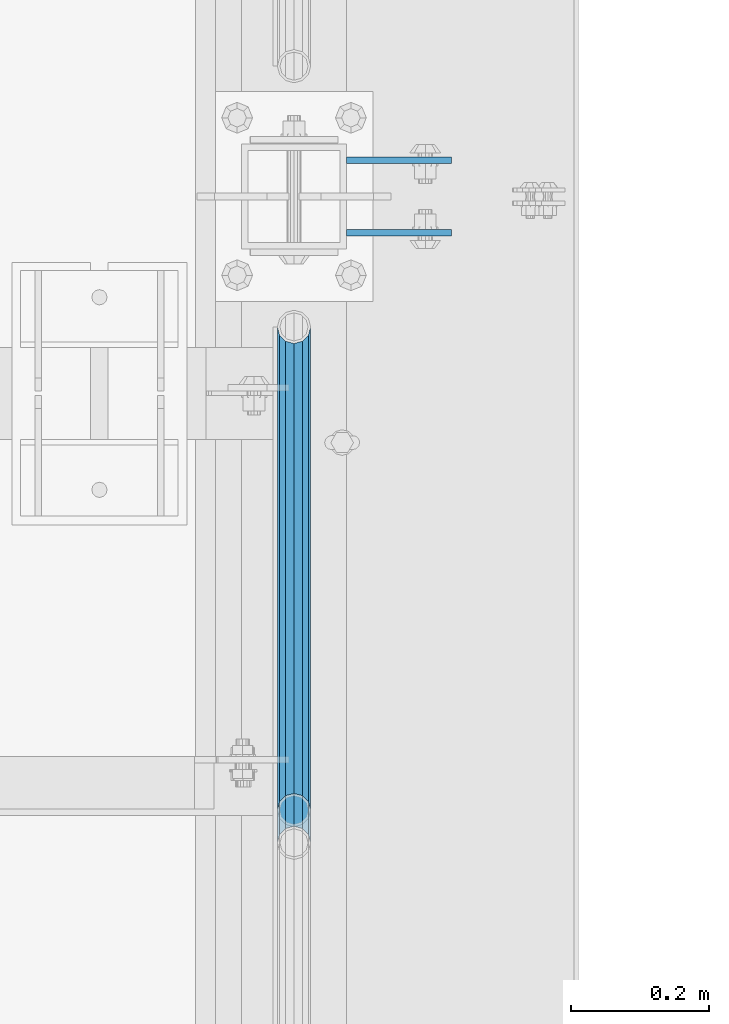
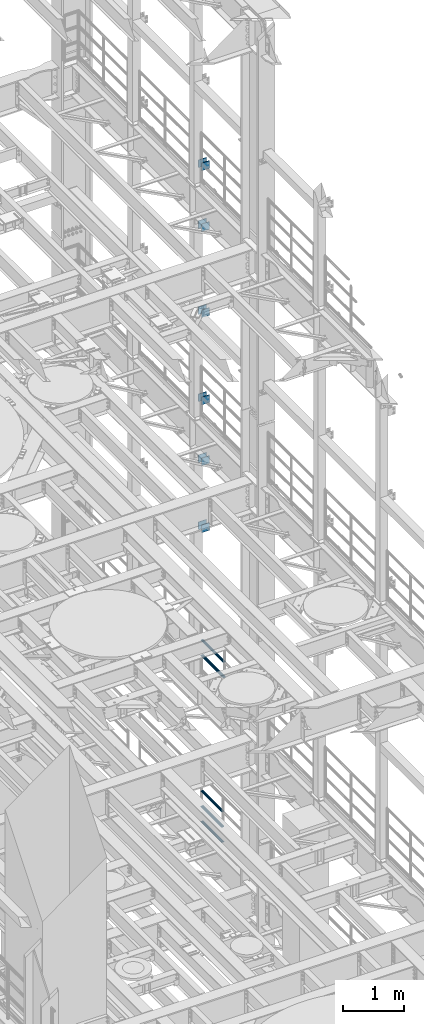
# One storey, part 1344 of 1876: 17 beams, 5 elements without a shape of their own.
"""IFC2X3 building model written with IfcOpenShell, lengths in millimetres."""

from ifc_helpers import new_model, si_unit, frame, origin_with_axes, place, context, subcontext, project, spatial, faceted_brep, material, type_object, element, aggregate, save


model = new_model("IFC2X3")

# Units and contexts
model_context = context("Model", 3, precision=1e-05, world=origin_with_axes())
body_context = subcontext(model_context, "Body", "Model", "MODEL_VIEW")
ifc_project = project(units=[si_unit("LENGTHUNIT", "METRE", prefix="MILLI"), si_unit("AREAUNIT", "SQUARE_METRE"), si_unit("VOLUMEUNIT", "CUBIC_METRE"), si_unit("MASSUNIT", "GRAM", prefix="KILO"), si_unit("TIMEUNIT", "SECOND"), si_unit("PLANEANGLEUNIT", "RADIAN"), si_unit("SOLIDANGLEUNIT", "STERADIAN"), si_unit("THERMODYNAMICTEMPERATUREUNIT", "DEGREE_CELSIUS"), si_unit("LUMINOUSINTENSITYUNIT", "LUMEN")], contexts=[model_context])

# Site, building, storey
site_placement = place(None, origin_with_axes())
site = spatial("IfcSite", under=ifc_project, at=site_placement, CompositionType="ELEMENT")
building_placement = place(site_placement, origin_with_axes())
building = spatial("IfcBuilding", under=site, at=building_placement, Name="Undefined", CompositionType="ELEMENT")
storey_placement = place(building_placement, origin_with_axes())
storey = spatial("IfcBuildingStorey", under=building, at=storey_placement, Name="Undefined", CompositionType="ELEMENT", Elevation=0.0)

# Assembly, beams
assembly_1_placement = place(storey_placement, origin_with_axes())
assembly_1 = element("IfcElementAssembly", 1, at=assembly_1_placement, inside=storey, Name="BEAM", AssemblyPlace="NOTDEFINED", PredefinedType="RIGID_FRAME")
ifc_material_1 = material(Name="STEEL/A36")
beam_type_1 = type_object("IfcBeamType", PredefinedType="NOTDEFINED")
beam_1_placement = place(assembly_1_placement, frame((7696.2, 9704.3875, 12369.8), z_axis=(0.0, 0.0, -1.0), x_axis=(1.0, 0.0, 0.0)))
beam_1 = element("IfcBeam", 2, at=beam_1_placement, type_object=beam_type_1, material=ifc_material_1, Name="PLATE", context=body_context, shape_type="Brep", body=[
    faceted_brep([(0.0, 4.76249999999982, -76.1999999999998), (3.63797880709171e-12, 4.76249999999982, 76.1999969482422), (152.399993896484, 4.76250000000073, 76.1999969482422), (152.4, 4.76249999999982, -76.1999999999998), (3.63797880709171e-12, -4.76249999999982, 76.1999969482422), (152.399993896484, -4.76250000000073, 76.1999969482422), (0.0, -4.76249999999982, -76.1999999999998), (152.4, -4.76249999999982, -76.1999999999998)], [[[0, 1, 2, 3]], [[4, 5, 2, 1]], [[4, 6, 7, 5]], [[6, 0, 3, 7]], [[5, 7, 3, 2]], [[6, 4, 1, 0]]]),
])
beam_2_placement = place(assembly_1_placement, frame((7696.2, 9599.6125, 12369.8), z_axis=(0.0, 0.0, -1.0), x_axis=(1.0, 0.0, 0.0)))
beam_2 = element("IfcBeam", 3, at=beam_2_placement, type_object=beam_type_1, material=ifc_material_1, Name="PLATE", context=body_context, shape_type="Brep", body=[
    faceted_brep([(0.0, 4.76249999999982, -76.1999999999998), (3.63797880709171e-12, 4.76249999999982, 76.1999969482422), (152.399993896484, 4.76250000000073, 76.1999969482422), (152.4, 4.76249999999982, -76.1999999999998), (3.63797880709171e-12, -4.76249999999982, 76.1999969482422), (152.399993896484, -4.76250000000073, 76.1999969482422), (0.0, -4.76249999999982, -76.1999999999998), (152.4, -4.76249999999982, -76.1999999999998)], [[[0, 1, 2, 3]], [[4, 5, 2, 1]], [[4, 6, 7, 5]], [[6, 0, 3, 7]], [[5, 7, 3, 2]], [[6, 4, 1, 0]]]),
])
beam_3_placement = place(assembly_1_placement, frame((7696.2, 9704.3875, 11029.95), z_axis=(0.0, 0.0, -1.0), x_axis=(1.0, 0.0, 0.0)))
beam_3 = element("IfcBeam", 4, at=beam_3_placement, type_object=beam_type_1, material=ifc_material_1, Name="PLATE", context=body_context, shape_type="Brep", body=[
    faceted_brep([(0.0, 4.76249999999982, -76.1999999999998), (3.63797880709171e-12, 4.76249999999982, 76.1999969482422), (152.399993896484, 4.76250000000073, 76.1999969482422), (152.4, 4.76249999999982, -76.1999999999998), (3.63797880709171e-12, -4.76249999999982, 76.1999969482422), (152.399993896484, -4.76250000000073, 76.1999969482422), (0.0, -4.76249999999982, -76.1999999999998), (152.4, -4.76249999999982, -76.1999999999998)], [[[0, 1, 2, 3]], [[4, 5, 2, 1]], [[4, 6, 7, 5]], [[6, 0, 3, 7]], [[5, 7, 3, 2]], [[6, 4, 1, 0]]]),
])
beam_4_placement = place(assembly_1_placement, frame((7696.2, 9599.6125, 11029.95), z_axis=(0.0, 0.0, -1.0), x_axis=(1.0, 0.0, 0.0)))
beam_4 = element("IfcBeam", 5, at=beam_4_placement, type_object=beam_type_1, material=ifc_material_1, Name="PLATE", context=body_context, shape_type="Brep", body=[
    faceted_brep([(0.0, 4.76249999999982, -76.1999999999998), (3.63797880709171e-12, 4.76249999999982, 76.1999969482422), (152.399993896484, 4.76250000000073, 76.1999969482422), (152.4, 4.76249999999982, -76.1999999999998), (3.63797880709171e-12, -4.76249999999982, 76.1999969482422), (152.399993896484, -4.76250000000073, 76.1999969482422), (0.0, -4.76249999999982, -76.1999999999998), (152.4, -4.76249999999982, -76.1999999999998)], [[[0, 1, 2, 3]], [[4, 5, 2, 1]], [[4, 6, 7, 5]], [[6, 0, 3, 7]], [[5, 7, 3, 2]], [[6, 4, 1, 0]]]),
])
aggregate(assembly_1, [beam_1, beam_2, beam_3, beam_4])

assembly_2_placement = place(storey_placement, origin_with_axes())
assembly_2 = element("IfcElementAssembly", 6, at=assembly_2_placement, inside=storey, Name="BEAM", AssemblyPlace="NOTDEFINED", PredefinedType="RIGID_FRAME")
beam_5_placement = place(assembly_2_placement, frame((7696.2, 9704.3875, 13589.0), z_axis=(0.0, 0.0, -1.0), x_axis=(1.0, 0.0, 0.0)))
beam_5 = element("IfcBeam", 7, at=beam_5_placement, type_object=beam_type_1, material=ifc_material_1, Name="PLATE", context=body_context, shape_type="Brep", body=[
    faceted_brep([(0.0, 4.76249999999982, -76.1999999999998), (3.63797880709171e-12, 4.76249999999982, 76.1999969482422), (152.399993896484, 4.76250000000073, 76.1999969482422), (152.4, 4.76249999999982, -76.1999999999998), (3.63797880709171e-12, -4.76249999999982, 76.1999969482422), (152.399993896484, -4.76250000000073, 76.1999969482422), (0.0, -4.76249999999982, -76.1999999999998), (152.4, -4.76249999999982, -76.1999999999998)], [[[0, 1, 2, 3]], [[4, 5, 2, 1]], [[4, 6, 7, 5]], [[6, 0, 3, 7]], [[5, 7, 3, 2]], [[6, 4, 1, 0]]]),
])
beam_6_placement = place(assembly_2_placement, frame((7696.2, 9599.6125, 13589.0), z_axis=(0.0, 0.0, -1.0), x_axis=(1.0, 0.0, 0.0)))
beam_6 = element("IfcBeam", 8, at=beam_6_placement, type_object=beam_type_1, material=ifc_material_1, Name="PLATE", context=body_context, shape_type="Brep", body=[
    faceted_brep([(0.0, 4.76249999999982, -76.1999999999998), (3.63797880709171e-12, 4.76249999999982, 76.1999969482422), (152.399993896484, 4.76250000000073, 76.1999969482422), (152.4, 4.76249999999982, -76.1999999999998), (3.63797880709171e-12, -4.76249999999982, 76.1999969482422), (152.399993896484, -4.76250000000073, 76.1999969482422), (0.0, -4.76249999999982, -76.1999999999998), (152.4, -4.76249999999982, -76.1999999999998)], [[[0, 1, 2, 3]], [[4, 5, 2, 1]], [[4, 6, 7, 5]], [[6, 0, 3, 7]], [[5, 7, 3, 2]], [[6, 4, 1, 0]]]),
])
beam_7_placement = place(assembly_2_placement, frame((7696.2, 9704.3875, 17056.1), z_axis=(0.0, 0.0, -1.0), x_axis=(1.0, 0.0, 0.0)))
beam_7 = element("IfcBeam", 9, at=beam_7_placement, type_object=beam_type_1, material=ifc_material_1, Name="PLATE", context=body_context, shape_type="Brep", body=[
    faceted_brep([(0.0, 4.76249999999982, -76.1999999999998), (3.63797880709171e-12, 4.76249999999982, 76.1999969482422), (152.399993896484, 4.76250000000073, 76.1999969482422), (152.4, 4.76249999999982, -76.1999999999998), (3.63797880709171e-12, -4.76249999999982, 76.1999969482422), (152.399993896484, -4.76250000000073, 76.1999969482422), (0.0, -4.76249999999982, -76.1999999999998), (152.4, -4.76249999999982, -76.1999999999998)], [[[0, 1, 2, 3]], [[4, 5, 2, 1]], [[4, 6, 7, 5]], [[6, 0, 3, 7]], [[5, 7, 3, 2]], [[6, 4, 1, 0]]]),
])
beam_8_placement = place(assembly_2_placement, frame((7696.2, 9599.6125, 17056.1), z_axis=(0.0, 0.0, -1.0), x_axis=(1.0, 0.0, 0.0)))
beam_8 = element("IfcBeam", 10, at=beam_8_placement, type_object=beam_type_1, material=ifc_material_1, Name="PLATE", context=body_context, shape_type="Brep", body=[
    faceted_brep([(0.0, 4.76249999999982, -76.1999999999998), (3.63797880709171e-12, 4.76249999999982, 76.1999969482422), (152.399993896484, 4.76250000000073, 76.1999969482422), (152.4, 4.76249999999982, -76.1999999999998), (3.63797880709171e-12, -4.76249999999982, 76.1999969482422), (152.399993896484, -4.76250000000073, 76.1999969482422), (0.0, -4.76249999999982, -76.1999999999998), (152.4, -4.76249999999982, -76.1999999999998)], [[[0, 1, 2, 3]], [[4, 5, 2, 1]], [[4, 6, 7, 5]], [[6, 0, 3, 7]], [[5, 7, 3, 2]], [[6, 4, 1, 0]]]),
])
beam_9_placement = place(assembly_2_placement, frame((7696.2, 9704.3875, 15335.25), z_axis=(0.0, 0.0, -1.0), x_axis=(1.0, 0.0, 0.0)))
beam_9 = element("IfcBeam", 11, at=beam_9_placement, type_object=beam_type_1, material=ifc_material_1, Name="PLATE", context=body_context, shape_type="Brep", body=[
    faceted_brep([(0.0, 4.76249999999982, -76.1999999999998), (3.63797880709171e-12, 4.76249999999982, 76.1999969482422), (152.399993896484, 4.76250000000073, 76.1999969482422), (152.4, 4.76249999999982, -76.1999999999998), (3.63797880709171e-12, -4.76249999999982, 76.1999969482422), (152.399993896484, -4.76250000000073, 76.1999969482422), (0.0, -4.76249999999982, -76.1999999999998), (152.4, -4.76249999999982, -76.1999999999998)], [[[0, 1, 2, 3]], [[4, 5, 2, 1]], [[4, 6, 7, 5]], [[6, 0, 3, 7]], [[5, 7, 3, 2]], [[6, 4, 1, 0]]]),
])
beam_10_placement = place(assembly_2_placement, frame((7696.2, 9599.6125, 15335.25), z_axis=(0.0, 0.0, -1.0), x_axis=(1.0, 0.0, 0.0)))
beam_10 = element("IfcBeam", 12, at=beam_10_placement, type_object=beam_type_1, material=ifc_material_1, Name="PLATE", context=body_context, shape_type="Brep", body=[
    faceted_brep([(0.0, 4.76249999999982, -76.1999999999998), (3.63797880709171e-12, 4.76249999999982, 76.1999969482422), (152.399993896484, 4.76250000000073, 76.1999969482422), (152.4, 4.76249999999982, -76.1999999999998), (3.63797880709171e-12, -4.76249999999982, 76.1999969482422), (152.399993896484, -4.76250000000073, 76.1999969482422), (0.0, -4.76249999999982, -76.1999999999998), (152.4, -4.76249999999982, -76.1999999999998)], [[[0, 1, 2, 3]], [[4, 5, 2, 1]], [[4, 6, 7, 5]], [[6, 0, 3, 7]], [[5, 7, 3, 2]], [[6, 4, 1, 0]]]),
])
aggregate(assembly_2, [beam_5, beam_6, beam_7, beam_8, beam_9, beam_10])

assembly_3_placement = place(storey_placement, origin_with_axes())
assembly_3 = element("IfcElementAssembly", 13, at=assembly_3_placement, inside=storey, Name="BEAM", AssemblyPlace="NOTDEFINED", PredefinedType="RIGID_FRAME")
beam_11_placement = place(assembly_3_placement, frame((7696.20000025489, 9704.3875, 18275.3), z_axis=(0.0, 0.0, -1.0), x_axis=(1.0, 0.0, 0.0)))
beam_11 = element("IfcBeam", 14, at=beam_11_placement, type_object=beam_type_1, material=ifc_material_1, Name="PLATE", context=body_context, shape_type="Brep", body=[
    faceted_brep([(0.0, 4.76249999999982, -76.1999999999998), (3.63797880709171e-12, 4.76249999999982, 76.1999969482422), (152.399993896484, 4.76250000000073, 76.1999969482422), (152.4, 4.76249999999982, -76.1999999999998), (3.63797880709171e-12, -4.76249999999982, 76.1999969482422), (152.399993896484, -4.76250000000073, 76.1999969482422), (0.0, -4.76249999999982, -76.1999999999998), (152.4, -4.76249999999982, -76.1999999999998)], [[[0, 1, 2, 3]], [[4, 5, 2, 1]], [[4, 6, 7, 5]], [[6, 0, 3, 7]], [[5, 7, 3, 2]], [[6, 4, 1, 0]]]),
])
beam_12_placement = place(assembly_3_placement, frame((7696.20000025489, 9599.6125, 18275.3), z_axis=(0.0, 0.0, -1.0), x_axis=(1.0, 0.0, 0.0)))
beam_12 = element("IfcBeam", 15, at=beam_12_placement, type_object=beam_type_1, material=ifc_material_1, Name="PLATE", context=body_context, shape_type="Brep", body=[
    faceted_brep([(0.0, 4.76249999999982, -76.1999999999998), (3.63797880709171e-12, 4.76249999999982, 76.1999969482422), (152.399993896484, 4.76250000000073, 76.1999969482422), (152.4, 4.76249999999982, -76.1999999999998), (3.63797880709171e-12, -4.76249999999982, 76.1999969482422), (152.399993896484, -4.76250000000073, 76.1999969482422), (0.0, -4.76249999999982, -76.1999999999998), (152.4, -4.76249999999982, -76.1999999999998)], [[[0, 1, 2, 3]], [[4, 5, 2, 1]], [[4, 6, 7, 5]], [[6, 0, 3, 7]], [[5, 7, 3, 2]], [[6, 4, 1, 0]]]),
])
aggregate(assembly_3, [beam_11, beam_12])

assembly_4_placement = place(storey_placement, origin_with_axes())
assembly_4 = element("IfcElementAssembly", 16, at=assembly_4_placement, inside=storey, Name="RAIL", AssemblyPlace="NOTDEFINED", PredefinedType="RIGID_FRAME")
ifc_material_2 = material()
beam_type_2 = type_object("IfcBeamType", Name="PIPE1-1/2SCH40", PredefinedType="NOTDEFINED")
beam_13_placement = place(assembly_4_placement, frame((7620.0, 8713.7875, 8620.125), z_axis=(0.0, 0.0, -1.0), x_axis=(0.0, 1.0, 0.0)))
beam_13 = element("IfcBeam", 17, at=beam_13_placement, type_object=beam_type_2, material=ifc_material_2, Name="RAIL", ObjectType="PIPE1-1/2SCH40", context=body_context, shape_type="Brep", body=[
    faceted_brep([(0.0, 24.1299999999992, 0.0), (12.0650000000064, 20.8971929933177, -12.0649999999987), (12.0650000000064, 20.8971929933177, 12.0649999999987), (12.0650000000064, -20.8971929933177, 12.0649999999987), (12.0650000000064, -20.8971929933177, -12.0649999999987), (0.0, -24.1299999999992, 0.0), (20.8971929933249, -12.0650000000005, 20.8971929933177), (20.8971929933249, -12.0650000000005, 15.8661214311796), (15.2545715621445, -17.7076214311801, 10.2235000000001), (12.5151929933249, -20.4470000000001, 0.0), (15.2545715621445, -17.7076214311801, -10.2235000000001), (20.8971929933249, -12.0650000000005, -15.8661214311796), (20.8971929933249, -12.0650000000005, -20.8971929933177), (24.1300000000063, 0.0, -20.4470000000001), (24.1300000000063, 0.0, -24.130000000001), (21.3906214311868, -10.2235000000001, -17.7076214311819), (21.3906214311868, 10.2235000000001, -17.7076214311819), (20.8971929933249, 12.0650000000005, -15.8661214311796), (20.8971929933249, 12.0650000000005, -20.8971929933177), (15.2545715621445, 17.7076214311801, -10.2235000000001), (12.5151929933249, 20.4470000000001, 0.0), (15.2545715621445, 17.7076214311801, 10.2235000000001), (20.8971929933249, 12.0650000000005, 15.8661214311796), (20.8971929933249, 12.0650000000005, 20.8971929933177), (21.3906214311868, 10.2235000000001, 17.7076214311819), (24.1300000000064, 0.0, 20.4470000000001), (24.1300000000064, 0.0, 24.130000000001), (21.3906214311868, -10.2235000000001, 17.7076214311819), (748.982500000002, 24.1300000000001, 0.0), (736.917500000002, 20.8971929933186, -12.0649999999987), (728.085307006683, 12.0649999999996, -20.8971929933177), (748.982500000002, -24.1300000000001, 0.0), (736.917500000002, -20.8971929933186, -12.0649999999987), (736.917500000002, -20.8971929933186, 12.0649999999987), (728.085307006683, -12.0649999999996, 20.8971929933177), (728.085307006683, -12.0649999999996, -20.8971929933177), (724.852500000002, 0.0, -24.130000000001), (727.591878568821, 10.2235000000001, -17.7076214311819), (724.852500000002, 0.0, -20.4470000000001), (728.085307006683, 12.0649999999996, -15.8661214311796), (728.085307006683, -12.0649999999996, -15.8661214311796), (727.591878568821, -10.2235000000001, -17.7076214311819), (733.727928437864, -17.7076214311801, -10.2235000000001), (736.467307006683, -20.4470000000001, 0.0), (733.727928437864, -17.7076214311801, 10.2235000000001), (728.085307006683, -12.0649999999996, 15.8661214311796), (727.591878568821, -10.2235000000001, 17.7076214311819), (724.852500000002, 0.0, 20.4470000000001), (724.852500000002, 0.0, 24.130000000001), (728.085307006683, 12.0649999999996, 20.8971929933177), (736.917500000002, 20.8971929933186, 12.0649999999987), (728.085307006683, 12.0649999999996, 15.8661214311796), (733.727928437864, 17.7076214311801, 10.2235000000001), (736.467307006683, 20.4470000000001, 0.0), (733.727928437864, 17.7076214311801, -10.2235000000001), (727.591878568821, 10.2235000000001, 17.7076214311819)], [[[0, 1, 2]], [[3, 4, 5]], [[6, 7, 8, 9, 10, 11, 12, 4, 3]], [[13, 14, 12, 11, 15]], [[16, 17, 18, 14, 13]], [[2, 1, 18, 17, 19, 20, 21, 22, 23]], [[23, 22, 24, 25, 26]], [[26, 25, 27, 7, 6]], [[1, 0, 28, 29]], [[18, 1, 29, 30]], [[31, 32, 33]], [[6, 3, 33, 34]], [[3, 5, 31, 33]], [[5, 4, 32, 31]], [[4, 12, 35, 32]], [[12, 14, 36, 35]], [[14, 18, 30, 36]], [[37, 38, 36, 30, 39]], [[40, 35, 36, 38, 41]], [[33, 32, 35, 40, 42, 43, 44, 45, 34]], [[34, 45, 46, 47, 48]], [[26, 6, 34, 48]], [[2, 23, 49, 50]], [[23, 26, 48, 49]], [[0, 2, 50, 28]], [[28, 50, 29]], [[49, 51, 52, 53, 54, 39, 30, 29, 50]], [[48, 47, 55, 51, 49]], [[25, 24, 55, 47]], [[55, 24, 22, 21, 52, 51]], [[21, 20, 53, 52]], [[20, 19, 54, 53]], [[19, 17, 16, 37, 39, 54]], [[16, 13, 38, 37]], [[13, 15, 41, 38]], [[41, 15, 11, 10, 42, 40]], [[10, 9, 43, 42]], [[9, 8, 44, 43]], [[8, 7, 27, 46, 45, 44]], [[27, 25, 47, 46]]]),
])
beam_14_placement = place(assembly_4_placement, frame((7620.0, 8713.7875, 8924.925), z_axis=(0.0, 0.0, -1.0), x_axis=(0.0, 1.0, 0.0)))
beam_14 = element("IfcBeam", 18, at=beam_14_placement, type_object=beam_type_2, material=ifc_material_2, Name="RAIL", ObjectType="PIPE1-1/2SCH40", context=body_context, shape_type="Brep", body=[
    faceted_brep([(0.0, 24.1299999999992, 0.0), (12.0650000000064, 20.8971929933177, -12.0649999999987), (12.0650000000064, 20.8971929933177, 12.0649999999987), (12.0650000000064, -20.8971929933177, 12.0649999999987), (12.0650000000064, -20.8971929933177, -12.0649999999987), (0.0, -24.1299999999992, 0.0), (20.8971929933249, -12.0650000000005, 20.8971929933177), (20.8971929933249, -12.0650000000005, 15.8661214311796), (15.2545715621445, -17.7076214311801, 10.2235000000001), (12.5151929933249, -20.4470000000001, 0.0), (15.2545715621445, -17.7076214311801, -10.2235000000001), (20.8971929933249, -12.0650000000005, -15.8661214311796), (20.8971929933249, -12.0650000000005, -20.8971929933177), (24.1300000000063, 0.0, -20.4470000000001), (24.1300000000063, 0.0, -24.130000000001), (21.3906214311868, -10.2235000000001, -17.7076214311819), (21.3906214311868, 10.2235000000001, -17.7076214311819), (20.8971929933249, 12.0650000000005, -15.8661214311796), (20.8971929933249, 12.0650000000005, -20.8971929933177), (15.2545715621445, 17.7076214311801, -10.2235000000001), (12.5151929933249, 20.4470000000001, 0.0), (15.2545715621445, 17.7076214311801, 10.2235000000001), (20.8971929933249, 12.0650000000005, 15.8661214311796), (20.8971929933249, 12.0650000000005, 20.8971929933177), (21.3906214311868, 10.2235000000001, 17.7076214311819), (24.1300000000064, 0.0, 20.4470000000001), (24.1300000000064, 0.0, 24.130000000001), (21.3906214311868, -10.2235000000001, 17.7076214311819), (748.982500000002, 24.1300000000001, 0.0), (736.917500000002, 20.8971929933186, -12.0649999999987), (728.085307006683, 12.0649999999996, -20.8971929933177), (748.982500000002, -24.1300000000001, 0.0), (736.917500000002, -20.8971929933186, -12.0649999999987), (736.917500000002, -20.8971929933186, 12.0649999999987), (728.085307006683, -12.0649999999996, 20.8971929933177), (728.085307006683, -12.0649999999996, -20.8971929933177), (724.852500000002, 0.0, -24.130000000001), (727.591878568821, 10.2235000000001, -17.7076214311819), (724.852500000002, 0.0, -20.4470000000001), (728.085307006683, 12.0649999999996, -15.8661214311796), (728.085307006683, -12.0649999999996, -15.8661214311796), (727.591878568821, -10.2235000000001, -17.7076214311819), (733.727928437864, -17.7076214311801, -10.2235000000001), (736.467307006683, -20.4470000000001, 0.0), (733.727928437864, -17.7076214311801, 10.2235000000001), (728.085307006683, -12.0649999999996, 15.8661214311796), (727.591878568821, -10.2235000000001, 17.7076214311819), (724.852500000002, 0.0, 20.4470000000001), (724.852500000002, 0.0, 24.130000000001), (728.085307006683, 12.0649999999996, 20.8971929933177), (736.917500000002, 20.8971929933186, 12.0649999999987), (728.085307006683, 12.0649999999996, 15.8661214311796), (733.727928437864, 17.7076214311801, 10.2235000000001), (736.467307006683, 20.4470000000001, 0.0), (733.727928437864, 17.7076214311801, -10.2235000000001), (727.591878568821, 10.2235000000001, 17.7076214311819)], [[[0, 1, 2]], [[3, 4, 5]], [[6, 7, 8, 9, 10, 11, 12, 4, 3]], [[13, 14, 12, 11, 15]], [[16, 17, 18, 14, 13]], [[2, 1, 18, 17, 19, 20, 21, 22, 23]], [[23, 22, 24, 25, 26]], [[26, 25, 27, 7, 6]], [[1, 0, 28, 29]], [[18, 1, 29, 30]], [[31, 32, 33]], [[6, 3, 33, 34]], [[3, 5, 31, 33]], [[5, 4, 32, 31]], [[4, 12, 35, 32]], [[12, 14, 36, 35]], [[14, 18, 30, 36]], [[37, 38, 36, 30, 39]], [[40, 35, 36, 38, 41]], [[33, 32, 35, 40, 42, 43, 44, 45, 34]], [[34, 45, 46, 47, 48]], [[26, 6, 34, 48]], [[2, 23, 49, 50]], [[23, 26, 48, 49]], [[0, 2, 50, 28]], [[28, 50, 29]], [[49, 51, 52, 53, 54, 39, 30, 29, 50]], [[48, 47, 55, 51, 49]], [[25, 24, 55, 47]], [[55, 24, 22, 21, 52, 51]], [[21, 20, 53, 52]], [[20, 19, 54, 53]], [[19, 17, 16, 37, 39, 54]], [[16, 13, 38, 37]], [[13, 15, 41, 38]], [[41, 15, 11, 10, 42, 40]], [[10, 9, 43, 42]], [[9, 8, 44, 43]], [[8, 7, 27, 46, 45, 44]], [[27, 25, 47, 46]]]),
])
aggregate(assembly_4, [beam_13, beam_14])

assembly_5_placement = place(storey_placement, origin_with_axes())
assembly_5 = element("IfcElementAssembly", 19, at=assembly_5_placement, inside=storey, Name="RAIL", AssemblyPlace="NOTDEFINED", PredefinedType="RIGID_FRAME")
beam_15_placement = place(assembly_5_placement, frame((7619.99999999999, 9462.76999999999, 5292.725), z_axis=(0.0, 0.0, 1.0), x_axis=(0.0, -1.0, 0.0)))
beam_15 = element("IfcBeam", 20, at=beam_15_placement, type_object=beam_type_2, material=ifc_material_2, Name="RAIL", ObjectType="PIPE1-1/2SCH40", context=body_context, shape_type="Brep", body=[
    faceted_brep([(680.460307006681, -12.0649999999996, 20.8971929933186), (680.460307006681, -12.0649999999914, 15.8661214311887), (679.966878568822, -10.2235000000001, 17.7076214311801), (677.2275, 0.0, 20.4470000000001), (677.2275, 0.0, 24.1300000000001), (679.966878568817, 10.2235000000001, 17.7076214311801), (680.460307006681, 12.0650000000078, 15.8661214311724), (680.460307006681, 12.0649999999996, 20.8971929933186), (701.3575, 24.1300000000001, 0.0), (689.2925, 20.8971929933186, 12.0649999999996), (689.2925, 20.8971929933186, -12.0649999999996), (686.102928437854, 17.7076214311801, 10.2235000000001), (688.842307006673, 20.4470000000001, 0.0), (686.102928437854, 17.7076214311801, -10.2235000000001), (680.460307006681, 12.0650000000078, -15.8661214311724), (680.460307006681, 12.0649999999996, -20.8971929933186), (679.966878568817, 10.2235000000001, -17.7076214311801), (677.2275, 0.0, -20.4470000000001), (677.2275, 0.0, -24.1300000000001), (680.460307006681, -12.0649999999914, -15.8661214311887), (680.460307006681, -12.0649999999996, -20.8971929933186), (679.966878568822, -10.2235000000001, -17.7076214311801), (701.3575, -24.1299999999919, 0.0), (689.2925, -20.8971929933186, -12.0649999999996), (689.2925, -20.8971929933186, 12.0649999999996), (686.10292843787, -17.7076214311801, -10.2235000000001), (688.842307006689, -20.4470000000001, 0.0), (686.10292843787, -17.7076214311801, 10.2235000000001), (12.0650000000064, -20.8971929933177, -12.0649999999987), (20.8971929933249, -12.0650000000005, -20.8971929933177), (0.0, 24.1299999999992, 0.0), (12.0650000000064, 20.8971929933177, -12.0649999999987), (12.0650000000064, 20.8971929933177, 12.0649999999987), (20.8971929933249, 12.0650000000005, 20.8971929933177), (24.1300000000064, 0.0, 24.130000000001), (20.8971929933249, 12.0650000000005, -20.8971929933177), (24.1300000000063, 0.0, -24.130000000001), (24.1300000000063, 0.0, -20.4470000000001), (20.8971929933249, -12.0650000000005, -15.8661214311796), (21.3906214311868, -10.2235000000001, -17.7076214311819), (21.3906214311868, 10.2235000000001, -17.7076214311819), (20.8971929933249, 12.0650000000005, -15.8661214311796), (15.2545715621445, 17.7076214311801, -10.2235000000001), (12.5151929933249, 20.4470000000001, 0.0), (15.2545715621445, 17.7076214311801, 10.2235000000001), (20.8971929933249, 12.0650000000005, 15.8661214311796), (21.3906214311868, 10.2235000000001, 17.7076214311819), (24.1300000000064, 0.0, 20.4470000000001), (21.3906214311868, -10.2235000000001, 17.7076214311819), (20.8971929933249, -12.0650000000005, 15.8661214311796), (20.8971929933249, -12.0650000000005, 20.8971929933177), (12.0650000000064, -20.8971929933177, 12.0649999999987), (0.0, -24.1299999999992, 0.0), (15.2545715621445, -17.7076214311801, 10.2235000000001), (12.5151929933249, -20.4470000000001, 0.0), (15.2545715621445, -17.7076214311801, -10.2235000000001)], [[[0, 1, 2, 3, 4]], [[4, 3, 5, 6, 7]], [[8, 9, 10]], [[7, 6, 11, 12, 13, 14, 15, 10, 9]], [[16, 17, 18, 15, 14]], [[19, 20, 18, 17, 21]], [[22, 23, 24]], [[24, 23, 20, 19, 25, 26, 27, 1, 0]], [[28, 29, 20, 23]], [[30, 31, 32]], [[33, 34, 4, 7]], [[32, 33, 7, 9]], [[30, 32, 9, 8]], [[31, 30, 8, 10]], [[35, 31, 10, 15]], [[36, 35, 15, 18]], [[29, 36, 18, 20]], [[37, 36, 29, 38, 39]], [[40, 41, 35, 36, 37]], [[32, 31, 35, 41, 42, 43, 44, 45, 33]], [[33, 45, 46, 47, 34]], [[34, 47, 48, 49, 50]], [[34, 50, 0, 4]], [[50, 51, 24, 0]], [[51, 52, 22, 24]], [[52, 28, 23, 22]], [[51, 28, 52]], [[50, 49, 53, 54, 55, 38, 29, 28, 51]], [[55, 54, 26, 25]], [[21, 39, 38, 55, 25, 19]], [[37, 39, 21, 17]], [[40, 37, 17, 16]], [[42, 41, 40, 16, 14, 13]], [[43, 42, 13, 12]], [[44, 43, 12, 11]], [[5, 46, 45, 44, 11, 6]], [[47, 46, 5, 3]], [[48, 47, 3, 2]], [[53, 49, 48, 2, 1, 27]], [[54, 53, 27, 26]]]),
])
beam_16_placement = place(assembly_5_placement, frame((7620.0, 8761.41249999999, 5597.525), z_axis=(0.0, 0.0, -1.0), x_axis=(0.0, 1.0, 0.0)))
beam_16 = element("IfcBeam", 21, at=beam_16_placement, type_object=beam_type_2, material=ifc_material_2, Name="RAIL", ObjectType="PIPE1-1/2SCH40", context=body_context, shape_type="Brep", body=[
    faceted_brep([(0.0, 24.1299999999992, 0.0), (12.0650000000064, 20.8971929933177, -12.0649999999987), (12.0650000000064, 20.8971929933177, 12.0649999999987), (12.0650000000064, -20.8971929933177, 12.0649999999987), (12.0650000000064, -20.8971929933177, -12.0649999999987), (0.0, -24.1299999999992, 0.0), (20.8971929933249, -12.0650000000005, 20.8971929933177), (20.8971929933249, -12.0650000000005, 15.8661214311796), (15.2545715621445, -17.7076214311801, 10.2235000000001), (12.5151929933249, -20.4470000000001, 0.0), (15.2545715621445, -17.7076214311801, -10.2235000000001), (20.8971929933249, -12.0650000000005, -15.8661214311796), (20.8971929933249, -12.0650000000005, -20.8971929933177), (24.1300000000063, 0.0, -20.4470000000001), (24.1300000000063, 0.0, -24.130000000001), (21.3906214311868, -10.2235000000001, -17.7076214311819), (21.3906214311868, 10.2235000000001, -17.7076214311819), (20.8971929933249, 12.0650000000005, -15.8661214311796), (20.8971929933249, 12.0650000000005, -20.8971929933177), (15.2545715621445, 17.7076214311801, -10.2235000000001), (12.5151929933249, 20.4470000000001, 0.0), (15.2545715621445, 17.7076214311801, 10.2235000000001), (20.8971929933249, 12.0650000000005, 15.8661214311796), (20.8971929933249, 12.0650000000005, 20.8971929933177), (21.3906214311868, 10.2235000000001, 17.7076214311819), (24.1300000000064, 0.0, 20.4470000000001), (24.1300000000064, 0.0, 24.130000000001), (21.3906214311868, -10.2235000000001, 17.7076214311819), (701.3575, 24.1300000000001, 0.0), (689.2925, 20.8971929933186, -12.0649999999996), (680.460307006681, 12.0649999999996, -20.8971929933186), (701.3575, -24.1299999999919, 0.0), (689.2925, -20.8971929933186, -12.0649999999996), (689.2925, -20.8971929933186, 12.0649999999996), (680.460307006681, -12.0649999999996, 20.8971929933186), (680.460307006681, -12.0649999999996, -20.8971929933186), (677.2275, 0.0, -24.1300000000001), (679.966878568817, 10.2235000000001, -17.7076214311801), (677.2275, 0.0, -20.4470000000001), (680.460307006681, 12.0650000000078, -15.8661214311724), (680.460307006681, -12.0649999999914, -15.8661214311887), (679.966878568822, -10.2235000000001, -17.7076214311801), (686.10292843787, -17.7076214311801, -10.2235000000001), (688.842307006689, -20.4470000000001, 0.0), (686.10292843787, -17.7076214311801, 10.2235000000001), (680.460307006681, -12.0649999999914, 15.8661214311887), (679.966878568822, -10.2235000000001, 17.7076214311801), (677.2275, 0.0, 20.4470000000001), (677.2275, 0.0, 24.1300000000001), (680.460307006681, 12.0649999999996, 20.8971929933186), (689.2925, 20.8971929933186, 12.0649999999996), (680.460307006681, 12.0650000000078, 15.8661214311724), (686.102928437854, 17.7076214311801, 10.2235000000001), (688.842307006673, 20.4470000000001, 0.0), (686.102928437854, 17.7076214311801, -10.2235000000001), (679.966878568817, 10.2235000000001, 17.7076214311801)], [[[0, 1, 2]], [[3, 4, 5]], [[6, 7, 8, 9, 10, 11, 12, 4, 3]], [[13, 14, 12, 11, 15]], [[16, 17, 18, 14, 13]], [[2, 1, 18, 17, 19, 20, 21, 22, 23]], [[23, 22, 24, 25, 26]], [[26, 25, 27, 7, 6]], [[1, 0, 28, 29]], [[18, 1, 29, 30]], [[31, 32, 33]], [[6, 3, 33, 34]], [[3, 5, 31, 33]], [[5, 4, 32, 31]], [[4, 12, 35, 32]], [[12, 14, 36, 35]], [[14, 18, 30, 36]], [[37, 38, 36, 30, 39]], [[40, 35, 36, 38, 41]], [[33, 32, 35, 40, 42, 43, 44, 45, 34]], [[34, 45, 46, 47, 48]], [[26, 6, 34, 48]], [[2, 23, 49, 50]], [[23, 26, 48, 49]], [[0, 2, 50, 28]], [[28, 50, 29]], [[49, 51, 52, 53, 54, 39, 30, 29, 50]], [[48, 47, 55, 51, 49]], [[25, 24, 55, 47]], [[55, 24, 22, 21, 52, 51]], [[21, 20, 53, 52]], [[20, 19, 54, 53]], [[19, 17, 16, 37, 39, 54]], [[16, 13, 38, 37]], [[13, 15, 41, 38]], [[41, 15, 11, 10, 42, 40]], [[10, 9, 43, 42]], [[9, 8, 44, 43]], [[8, 7, 27, 46, 45, 44]], [[27, 25, 47, 46]]]),
])
beam_17_placement = place(assembly_5_placement, frame((7620.0, 8761.41249999999, 5902.325), z_axis=(0.0, 0.0, -1.0), x_axis=(0.0, 1.0, 0.0)))
beam_17 = element("IfcBeam", 22, at=beam_17_placement, type_object=beam_type_2, material=ifc_material_2, Name="RAIL", ObjectType="PIPE1-1/2SCH40", context=body_context, shape_type="Brep", body=[
    faceted_brep([(0.0, 24.1299999999992, 0.0), (12.0650000000064, 20.8971929933177, -12.0649999999987), (12.0650000000064, 20.8971929933177, 12.0649999999987), (12.0650000000064, -20.8971929933177, 12.0649999999987), (12.0650000000064, -20.8971929933177, -12.0649999999987), (0.0, -24.1299999999992, 0.0), (20.8971929933249, -12.0650000000005, 20.8971929933177), (20.8971929933249, -12.0650000000005, 15.8661214311796), (15.2545715621445, -17.7076214311801, 10.2235000000001), (12.5151929933249, -20.4470000000001, 0.0), (15.2545715621445, -17.7076214311801, -10.2235000000001), (20.8971929933249, -12.0650000000005, -15.8661214311796), (20.8971929933249, -12.0650000000005, -20.8971929933177), (24.1300000000063, 0.0, -20.4470000000001), (24.1300000000063, 0.0, -24.130000000001), (21.3906214311868, -10.2235000000001, -17.7076214311819), (21.3906214311868, 10.2235000000001, -17.7076214311819), (20.8971929933249, 12.0650000000005, -15.8661214311796), (20.8971929933249, 12.0650000000005, -20.8971929933177), (15.2545715621445, 17.7076214311801, -10.2235000000001), (12.5151929933249, 20.4470000000001, 0.0), (15.2545715621445, 17.7076214311801, 10.2235000000001), (20.8971929933249, 12.0650000000005, 15.8661214311796), (20.8971929933249, 12.0650000000005, 20.8971929933177), (21.3906214311868, 10.2235000000001, 17.7076214311819), (24.1300000000064, 0.0, 20.4470000000001), (24.1300000000064, 0.0, 24.130000000001), (21.3906214311868, -10.2235000000001, 17.7076214311819), (701.3575, 24.1300000000001, 0.0), (689.2925, 20.8971929933186, -12.0649999999996), (680.460307006681, 12.0649999999996, -20.8971929933186), (701.3575, -24.1299999999919, 0.0), (689.2925, -20.8971929933186, -12.0649999999996), (689.2925, -20.8971929933186, 12.0649999999996), (680.460307006681, -12.0649999999996, 20.8971929933186), (680.460307006681, -12.0649999999996, -20.8971929933186), (677.2275, 0.0, -24.1300000000001), (679.966878568817, 10.2235000000001, -17.7076214311801), (677.2275, 0.0, -20.4470000000001), (680.460307006681, 12.0650000000078, -15.8661214311724), (680.460307006681, -12.0649999999914, -15.8661214311887), (679.966878568822, -10.2235000000001, -17.7076214311801), (686.10292843787, -17.7076214311801, -10.2235000000001), (688.842307006689, -20.4470000000001, 0.0), (686.10292843787, -17.7076214311801, 10.2235000000001), (680.460307006681, -12.0649999999914, 15.8661214311887), (679.966878568822, -10.2235000000001, 17.7076214311801), (677.2275, 0.0, 20.4470000000001), (677.2275, 0.0, 24.1300000000001), (680.460307006681, 12.0649999999996, 20.8971929933186), (689.2925, 20.8971929933186, 12.0649999999996), (680.460307006681, 12.0650000000078, 15.8661214311724), (686.102928437854, 17.7076214311801, 10.2235000000001), (688.842307006673, 20.4470000000001, 0.0), (686.102928437854, 17.7076214311801, -10.2235000000001), (679.966878568817, 10.2235000000001, 17.7076214311801)], [[[0, 1, 2]], [[3, 4, 5]], [[6, 7, 8, 9, 10, 11, 12, 4, 3]], [[13, 14, 12, 11, 15]], [[16, 17, 18, 14, 13]], [[2, 1, 18, 17, 19, 20, 21, 22, 23]], [[23, 22, 24, 25, 26]], [[26, 25, 27, 7, 6]], [[1, 0, 28, 29]], [[18, 1, 29, 30]], [[31, 32, 33]], [[6, 3, 33, 34]], [[3, 5, 31, 33]], [[5, 4, 32, 31]], [[4, 12, 35, 32]], [[12, 14, 36, 35]], [[14, 18, 30, 36]], [[37, 38, 36, 30, 39]], [[40, 35, 36, 38, 41]], [[33, 32, 35, 40, 42, 43, 44, 45, 34]], [[34, 45, 46, 47, 48]], [[26, 6, 34, 48]], [[2, 23, 49, 50]], [[23, 26, 48, 49]], [[0, 2, 50, 28]], [[28, 50, 29]], [[49, 51, 52, 53, 54, 39, 30, 29, 50]], [[48, 47, 55, 51, 49]], [[25, 24, 55, 47]], [[55, 24, 22, 21, 52, 51]], [[21, 20, 53, 52]], [[20, 19, 54, 53]], [[19, 17, 16, 37, 39, 54]], [[16, 13, 38, 37]], [[13, 15, 41, 38]], [[41, 15, 11, 10, 42, 40]], [[10, 9, 43, 42]], [[9, 8, 44, 43]], [[8, 7, 27, 46, 45, 44]], [[27, 25, 47, 46]]]),
])
aggregate(assembly_5, [beam_15, beam_16, beam_17])

save(model, "model.ifc")
